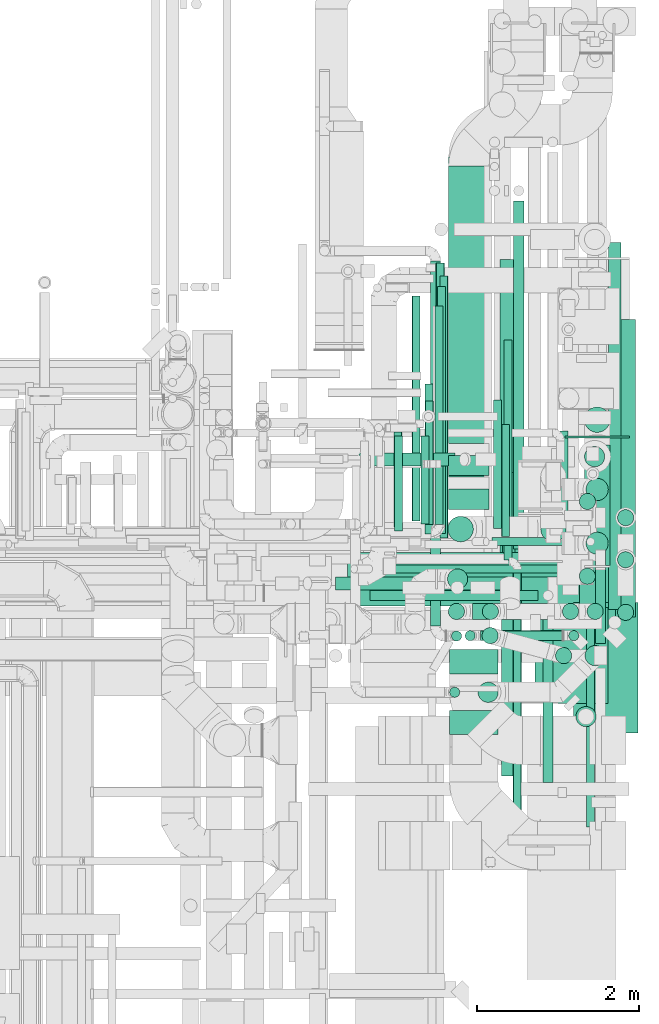
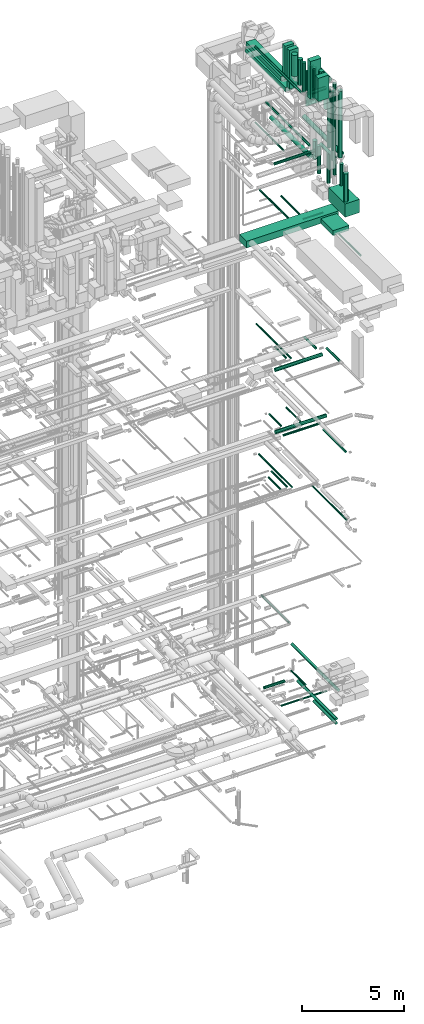
# One storey, part 82 of 337: 70 flow segments, 1 flow fitting.
"""IFC2X3 building model written with IfcOpenShell, lengths in millimetres."""

from ifc_helpers import new_model, entity, si_unit, converted_unit, derived_unit, direction, frame, origin, origin_2d_with_axis, place, context, subcontext, project, spatial, rectangle, circle, extrude, source, transform, mapped, material, type_object, type_shapes, element, save


model = new_model("IFC2X3")

# Units and contexts
model_context = context("Model", 3, precision=0.01, world=origin(), true_north=direction((6.12303176911189e-17, 1.0)))
body_context = subcontext(model_context, "Body", "Model", "MODEL_VIEW")
ifc_project = project(units=[si_unit("LENGTHUNIT", "METRE", prefix="MILLI"), si_unit("AREAUNIT", "SQUARE_METRE"), si_unit("VOLUMEUNIT", "CUBIC_METRE"), converted_unit("PLANEANGLEUNIT", "DEGREE", entity("IfcRatioMeasure", 0.0174532925199433), si_unit("PLANEANGLEUNIT", "RADIAN"), dimensions=[0, 0, 0, 0, 0, 0, 0]), si_unit("MASSUNIT", "GRAM", prefix="KILO"), derived_unit("MASSDENSITYUNIT", [(si_unit("MASSUNIT", "GRAM", prefix="KILO"), 1), (si_unit("LENGTHUNIT", "METRE"), -3)]), derived_unit("MOMENTOFINERTIAUNIT", [(si_unit("LENGTHUNIT", "METRE"), 4)]), si_unit("TIMEUNIT", "SECOND"), si_unit("FREQUENCYUNIT", "HERTZ"), si_unit("THERMODYNAMICTEMPERATUREUNIT", "DEGREE_CELSIUS"), derived_unit("THERMALTRANSMITTANCEUNIT", [(si_unit("MASSUNIT", "GRAM", prefix="KILO"), 1), (si_unit("THERMODYNAMICTEMPERATUREUNIT", "KELVIN"), -1), (si_unit("TIMEUNIT", "SECOND"), -3)]), derived_unit("VOLUMETRICFLOWRATEUNIT", [(si_unit("LENGTHUNIT", "METRE"), 3), (si_unit("TIMEUNIT", "SECOND"), -1)]), derived_unit("MASSFLOWRATEUNIT", [(si_unit("MASSUNIT", "GRAM", prefix="KILO"), 1), (si_unit("TIMEUNIT", "SECOND"), -1)]), derived_unit("ROTATIONALFREQUENCYUNIT", [(si_unit("TIMEUNIT", "SECOND"), -1)]), si_unit("ELECTRICCURRENTUNIT", "AMPERE"), si_unit("ELECTRICVOLTAGEUNIT", "VOLT"), si_unit("POWERUNIT", "WATT"), si_unit("FORCEUNIT", "NEWTON", prefix="KILO"), si_unit("ILLUMINANCEUNIT", "LUX"), si_unit("LUMINOUSFLUXUNIT", "LUMEN"), si_unit("LUMINOUSINTENSITYUNIT", "CANDELA"), derived_unit("USERDEFINED", [(si_unit("MASSUNIT", "GRAM", prefix="KILO"), -1), (si_unit("LENGTHUNIT", "METRE"), -2), (si_unit("TIMEUNIT", "SECOND"), 3), (si_unit("LUMINOUSFLUXUNIT", "LUMEN"), 1)]), derived_unit("LINEARVELOCITYUNIT", [(si_unit("LENGTHUNIT", "METRE"), 1), (si_unit("TIMEUNIT", "SECOND"), -1)]), si_unit("PRESSUREUNIT", "PASCAL"), derived_unit("USERDEFINED", [(si_unit("LENGTHUNIT", "METRE"), -2), (si_unit("MASSUNIT", "GRAM", prefix="KILO"), 1), (si_unit("TIMEUNIT", "SECOND"), -2)]), derived_unit("LINEARFORCEUNIT", [(si_unit("MASSUNIT", "GRAM", prefix="KILO"), 1), (si_unit("LENGTHUNIT", "METRE"), 1), (si_unit("TIMEUNIT", "SECOND"), -2), (si_unit("LENGTHUNIT", "METRE"), -1)]), derived_unit("PLANARFORCEUNIT", [(si_unit("MASSUNIT", "GRAM", prefix="KILO"), 1), (si_unit("LENGTHUNIT", "METRE"), 1), (si_unit("TIMEUNIT", "SECOND"), -2), (si_unit("LENGTHUNIT", "METRE"), -2)])], contexts=[model_context])

# Site, building, storey
site_placement = place(None, origin())
site = spatial("IfcSite", under=ifc_project, at=site_placement, CompositionType="ELEMENT")
building_placement = place(site_placement, origin())
building = spatial("IfcBuilding", under=site, at=building_placement, CompositionType="ELEMENT")
storey_placement = place(building_placement, origin())
storey = spatial("IfcBuildingStorey", under=building, at=storey_placement, CompositionType="ELEMENT", Elevation=0.0)

# Flow segments
duct_segment_type_1 = type_object("IfcDuctSegmentType", PredefinedType="NOTDEFINED")
flow_segment_1_placement = place(storey_placement, frame((67791.64, 9413.98, 27350.0)))
element("IfcFlowSegment", 1, at=flow_segment_1_placement, inside=storey, type_object=duct_segment_type_1, context=body_context, shape_type="SweptSolid", body=[
    extrude(rectangle(XDim=5190.00000000013, YDim=700.0, at=origin_2d_with_axis()), frame((2595.0, 350.0, 0.0)), (0.0, 0.0, 1.0), 399.999999999996),
])
flow_segment_2_placement = place(storey_placement, frame((71975.78, 8207.23, 27350.0)))
element("IfcFlowSegment", 2, at=flow_segment_2_placement, inside=storey, type_object=duct_segment_type_1, context=body_context, shape_type="SweptSolid", body=[
    extrude(rectangle(XDim=1186.60983195998, YDim=899.999999999999, at=origin_2d_with_axis()), frame((450.08, 593.37, 0.0), z_axis=(0.0, 0.0, 1.0), x_axis=(-0.000134105140809168, 0.999999991007906, 0.0)), (0.0, 0.0, 1.0), 300.000000000001),
])
flow_segment_3_placement = place(storey_placement, frame((70919.75, 7823.58, 35950.0)))
element("IfcFlowSegment", 3, at=flow_segment_3_placement, inside=storey, type_object=duct_segment_type_1, context=body_context, shape_type="SweptSolid", body=[
    extrude(rectangle(XDim=300.000000000001, YDim=600.000000000002, at=origin_2d_with_axis()), frame((300.0, 150.0, 0.0), z_axis=(0.0, 0.0, 1.0), x_axis=(0.0, -1.0, 0.0)), (0.0, 0.0, 1.0), 1380.0),
])
flow_segment_4_placement = place(storey_placement, frame((70919.75, 8574.98, 35600.0)))
element("IfcFlowSegment", 4, at=flow_segment_4_placement, inside=storey, type_object=duct_segment_type_1, context=body_context, shape_type="SweptSolid", body=[
    extrude(rectangle(XDim=300.000000000001, YDim=600.000000000002, at=origin_2d_with_axis()), frame((300.0, 150.0, 0.0), z_axis=(0.0, 0.0, 1.0), x_axis=(0.0, -1.0, 0.0)), (0.0, 0.0, 1.0), 2280.00000000001),
])
flow_segment_5_placement = place(storey_placement, frame((70907.48, 11425.0, 35010.0)))
element("IfcFlowSegment", 5, at=flow_segment_5_placement, inside=storey, type_object=duct_segment_type_1, context=body_context, shape_type="SweptSolid", body=[
    extrude(rectangle(XDim=3428.6189352427, YDim=499.999999999999, at=origin_2d_with_axis()), frame((250.0, 1714.31, 0.0), z_axis=(0.0, 0.0, 1.0), x_axis=(0.0, -1.0, 0.0)), (0.0, 0.0, 1.0), 250.000000000004),
])
flow_segment_6_placement = place(storey_placement, frame((70907.48, 11025.0, 35410.0)))
element("IfcFlowSegment", 6, at=flow_segment_6_placement, inside=storey, type_object=duct_segment_type_1, context=body_context, shape_type="SweptSolid", body=[
    extrude(rectangle(XDim=249.999999999999, YDim=499.999999999999, at=origin_2d_with_axis()), frame((250.0, 125.0, 0.0), z_axis=(0.0, 0.0, 1.0), x_axis=(0.0, 1.0, 0.0)), (0.0, 0.0, 1.0), 1905.00000000002),
])
flow_segment_7_placement = place(storey_placement, frame((70907.48, 11008.7, 34600.0)))
element("IfcFlowSegment", 7, at=flow_segment_7_placement, inside=storey, type_object=duct_segment_type_1, context=body_context, shape_type="SweptSolid", body=[
    extrude(rectangle(XDim=3954.30436019193, YDim=499.999999999999, at=origin_2d_with_axis()), frame((250.0, 1977.15, 0.0), z_axis=(0.0, 0.0, 1.0), x_axis=(0.0, -1.0, 0.0)), (0.0, 0.0, 1.0), 250.000000000004),
])
flow_segment_8_placement = place(storey_placement, frame((70907.48, 10608.7, 35000.0)))
element("IfcFlowSegment", 8, at=flow_segment_8_placement, inside=storey, type_object=duct_segment_type_1, context=body_context, shape_type="SweptSolid", body=[
    extrude(rectangle(XDim=249.999999999999, YDim=499.999999999999, at=origin_2d_with_axis()), frame((250.0, 125.0, 0.0), z_axis=(0.0, 0.0, 1.0), x_axis=(0.0, 1.0, 0.0)), (0.0, 0.0, 1.0), 2315.0),
])
flow_segment_9_placement = place(storey_placement, frame((72448.65, 7845.08, 28500.0)))
element("IfcFlowSegment", 9, at=flow_segment_9_placement, inside=storey, type_object=duct_segment_type_1, context=body_context, shape_type="SweptSolid", body=[
    extrude(rectangle(XDim=1610.00000000001, YDim=800.0, at=origin_2d_with_axis()), frame((400.0, 805.0, 0.0), z_axis=(0.0, 0.0, 1.0), x_axis=(0.0, -1.0, 0.0)), (0.0, 0.0, 1.0), 800.0),
])
duct_segment_type_2 = type_object("IfcDuctSegmentType", PredefinedType="NOTDEFINED")
flow_segment_10_placement = place(storey_placement, frame((72879.66, 9371.8, -881.6)))
element("IfcFlowSegment", 10, at=flow_segment_10_placement, inside=storey, type_object=duct_segment_type_2, context=body_context, shape_type="SweptSolid", body=[
    extrude(circle(Radius=80.0, at=origin_2d_with_axis()), frame((81.6, 0.0, 81.6), z_axis=(0.0, 1.0, 0.0), x_axis=(-1.0, 0.0, 0.0)), (0.0, 0.0, 1.0), 4537.92989),
])
flow_segment_11_placement = place(storey_placement, frame((69801.87, 11141.98, -756.6)))
element("IfcFlowSegment", 11, at=flow_segment_11_placement, inside=storey, type_object=duct_segment_type_2, context=body_context, shape_type="SweptSolid", body=[
    extrude(circle(Radius=80.0, at=origin_2d_with_axis()), frame((0.0, 81.6, 81.6), z_axis=(1.0, 0.0, 0.0), x_axis=(0.0, -1.0, 0.0)), (0.0, 0.0, 1.0), 1181.52376700002),
])
flow_segment_12_placement = place(storey_placement, frame((71568.5, 7314.74, -881.6)))
element("IfcFlowSegment", 12, at=flow_segment_12_placement, inside=storey, type_object=duct_segment_type_2, context=body_context, shape_type="SweptSolid", body=[
    extrude(circle(Radius=80.0, at=origin_2d_with_axis()), frame((81.6, 0.0, 81.6), z_axis=(0.0, 1.0, 0.0), x_axis=(-1.0, 0.0, 0.0)), (0.0, 0.0, 1.0), 3748.83497000008),
])
flow_segment_13_placement = place(storey_placement, frame((70010.28, 9821.97, -1051.6)))
element("IfcFlowSegment", 13, at=flow_segment_13_placement, inside=storey, type_object=duct_segment_type_2, context=body_context, shape_type="SweptSolid", body=[
    extrude(circle(Radius=50.0, at=origin_2d_with_axis()), frame((0.0, 51.6, 51.6), z_axis=(1.0, 0.0, 0.0), x_axis=(0.0, -1.0, 0.0)), (0.0, 0.0, 1.0), 2578.23126866774),
])
flow_segment_14_placement = place(storey_placement, frame((71561.03, 10274.06, -601.6)))
element("IfcFlowSegment", 14, at=flow_segment_14_placement, inside=storey, type_object=duct_segment_type_2, context=body_context, shape_type="SweptSolid", body=[
    extrude(circle(Radius=50.0, at=origin_2d_with_axis()), frame((51.6, 0.0, 51.6), z_axis=(2.56859086930135e-06, 1.0, 0.0), x_axis=(1.0, -2.56859086930135e-06, 0.0)), (0.0, 0.0, 1.0), 1382.69073369446),
])
flow_segment_15_placement = place(storey_placement, frame((71557.44, 7311.16, -1131.6)))
element("IfcFlowSegment", 15, at=flow_segment_15_placement, inside=storey, type_object=duct_segment_type_2, context=body_context, shape_type="SweptSolid", body=[
    extrude(circle(Radius=80.0, at=origin_2d_with_axis()), frame((81.6, 0.0, 81.6), z_axis=(0.0, 1.0, 0.0), x_axis=(-1.0, 0.0, 0.0)), (0.0, 0.0, 1.0), 2169.84771),
])
flow_segment_16_placement = place(storey_placement, frame((70238.12, 10340.36, 15248.4)))
element("IfcFlowSegment", 16, at=flow_segment_16_placement, inside=storey, type_object=duct_segment_type_2, context=body_context, shape_type="SweptSolid", body=[
    extrude(circle(Radius=50.0, at=origin_2d_with_axis()), frame((51.6, 0.0, 51.6), z_axis=(0.0, 1.0, 0.0), x_axis=(1.0, 0.0, 0.0)), (0.0, 0.0, 1.0), 1177.73964999999),
])
flow_segment_17_placement = place(storey_placement, frame((69737.94, 9873.39, 15248.4)))
element("IfcFlowSegment", 17, at=flow_segment_17_placement, inside=storey, type_object=duct_segment_type_2, context=body_context, shape_type="SweptSolid", body=[
    extrude(circle(Radius=100.0, at=origin_2d_with_axis()), frame((0.0, 101.6, 101.6), z_axis=(1.0, 0.0, 0.0), x_axis=(0.0, -1.0, 0.0)), (0.0, 0.0, 1.0), 2869.63437025001),
])
flow_segment_18_placement = place(storey_placement, frame((69936.58, 9480.25, 15285.9)))
element("IfcFlowSegment", 18, at=flow_segment_18_placement, inside=storey, type_object=duct_segment_type_2, context=body_context, shape_type="SweptSolid", body=[
    extrude(circle(Radius=62.5, at=origin_2d_with_axis()), frame((0.0, 64.1, 64.1), z_axis=(1.0, 0.0, 0.0), x_axis=(0.0, 1.0, 0.0)), (0.0, 0.0, 1.0), 2073.83664918466),
])
flow_segment_19_placement = place(storey_placement, frame((72071.32, 7232.82, 14935.9)))
element("IfcFlowSegment", 19, at=flow_segment_19_placement, inside=storey, type_object=duct_segment_type_2, context=body_context, shape_type="SweptSolid", body=[
    extrude(circle(Radius=62.5, at=origin_2d_with_axis()), frame((64.1, 0.0, 64.1), z_axis=(0.0, 1.0, 0.0), x_axis=(-1.0, 0.0, 0.0)), (0.0, 0.0, 1.0), 2186.51993999997),
])
flow_segment_20_placement = place(storey_placement, frame((71703.29, 6486.79, 11468.4)))
element("IfcFlowSegment", 20, at=flow_segment_20_placement, inside=storey, type_object=duct_segment_type_2, context=body_context, shape_type="SweptSolid", body=[
    extrude(circle(Radius=50.0, at=origin_2d_with_axis()), frame((51.6, 0.0, 51.6), z_axis=(0.0, 1.0, 0.0), x_axis=(-1.0, 0.0, 0.0)), (0.0, 0.0, 1.0), 3380.00000000001),
])
flow_segment_21_placement = place(storey_placement, frame((70227.31, 10391.33, 11448.4)))
element("IfcFlowSegment", 21, at=flow_segment_21_placement, inside=storey, type_object=duct_segment_type_2, context=body_context, shape_type="SweptSolid", body=[
    extrude(circle(Radius=50.0, at=origin_2d_with_axis()), frame((51.6, 0.0, 51.6), z_axis=(0.0, 1.0, 0.0), x_axis=(-1.0, 0.0, 0.0)), (0.0, 0.0, 1.0), 1175.00000000004),
])
flow_segment_22_placement = place(storey_placement, frame((70616.5, 10421.33, 11448.4)))
element("IfcFlowSegment", 22, at=flow_segment_22_placement, inside=storey, type_object=duct_segment_type_2, context=body_context, shape_type="SweptSolid", body=[
    extrude(circle(Radius=50.0, at=origin_2d_with_axis()), frame((51.6, 0.0, 51.6), z_axis=(0.0, 1.0, 0.0), x_axis=(-1.0, 0.0, 0.0)), (0.0, 0.0, 1.0), 1529.47216173019),
])
flow_segment_23_placement = place(storey_placement, frame((70796.11, 10255.6, 11468.4)))
element("IfcFlowSegment", 23, at=flow_segment_23_placement, inside=storey, type_object=duct_segment_type_2, context=body_context, shape_type="SweptSolid", body=[
    extrude(circle(Radius=50.0, at=origin_2d_with_axis()), frame((51.6, 0.0, 51.6), z_axis=(0.0, 1.0, 0.0), x_axis=(1.0, 0.0, 0.0)), (0.0, 0.0, 1.0), 3240.00000000001),
])
flow_segment_24_placement = place(storey_placement, frame((72720.06, 8953.57, 19085.9)))
element("IfcFlowSegment", 24, at=flow_segment_24_placement, inside=storey, type_object=duct_segment_type_2, context=body_context, shape_type="SweptSolid", body=[
    extrude(circle(Radius=62.5, at=origin_2d_with_axis()), frame((64.1, 0.0, 64.1), z_axis=(0.0, 1.0, 0.0), x_axis=(1.0, 0.0, 0.0)), (0.0, 0.0, 1.0), 1265.62499999999),
])
flow_segment_25_placement = place(storey_placement, frame((72256.63, 10469.2, 19085.9)))
element("IfcFlowSegment", 25, at=flow_segment_25_placement, inside=storey, type_object=duct_segment_type_2, context=body_context, shape_type="SweptSolid", body=[
    extrude(circle(Radius=62.5, at=origin_2d_with_axis()), frame((64.1, 0.0, 64.1), z_axis=(0.0, 1.0, 0.0), x_axis=(1.0, 0.0, 0.0)), (0.0, 0.0, 1.0), 1109.37500000001),
])
flow_segment_26_placement = place(storey_placement, frame((70752.21, 10279.05, 19148.4)))
element("IfcFlowSegment", 26, at=flow_segment_26_placement, inside=storey, type_object=duct_segment_type_2, context=body_context, shape_type="SweptSolid", body=[
    extrude(circle(Radius=50.0, at=origin_2d_with_axis()), frame((51.6, 0.0, 51.6), z_axis=(0.0, 1.0, 0.0), x_axis=(1.0, 0.0, 0.0)), (0.0, 0.0, 1.0), 3376.25000000001),
])
flow_segment_27_placement = place(storey_placement, frame((70563.23, 10425.19, 19148.4)))
element("IfcFlowSegment", 27, at=flow_segment_27_placement, inside=storey, type_object=duct_segment_type_2, context=body_context, shape_type="SweptSolid", body=[
    extrude(circle(Radius=50.0, at=origin_2d_with_axis()), frame((51.6, 0.0, 51.6), z_axis=(0.0, 1.0, 0.0), x_axis=(1.0, 0.0, 0.0)), (0.0, 0.0, 1.0), 1090.00000000002),
])
flow_segment_28_placement = place(storey_placement, frame((71459.59, 10375.04, 14948.4)))
element("IfcFlowSegment", 28, at=flow_segment_28_placement, inside=storey, type_object=duct_segment_type_2, context=body_context, shape_type="SweptSolid", body=[
    extrude(circle(Radius=50.0, at=origin_2d_with_axis()), frame((51.6, 0.0, 51.6), z_axis=(0.0, 1.0, 0.0), x_axis=(1.0, 0.0, 0.0)), (0.0, 0.0, 1.0), 1585.30000000002),
])
flow_segment_29_placement = place(storey_placement, frame((69656.48, 9772.48, 19048.4)))
element("IfcFlowSegment", 29, at=flow_segment_29_placement, inside=storey, type_object=duct_segment_type_2, context=body_context, shape_type="SweptSolid", body=[
    extrude(circle(Radius=100.0, at=origin_2d_with_axis()), frame((0.0, 101.6, 101.6), z_axis=(1.0, 0.0, 0.0), x_axis=(0.0, -1.0, 0.0)), (0.0, 0.0, 1.0), 2660.0),
])
flow_segment_30_placement = place(storey_placement, frame((72591.89, 8674.15, 31450.0)))
element("IfcFlowSegment", 30, at=flow_segment_30_placement, inside=storey, type_object=duct_segment_type_2, context=body_context, shape_type="SweptSolid", body=[
    extrude(circle(Radius=125.0, at=origin_2d_with_axis()), frame((126.6, 126.6, 0.0), z_axis=(0.0, 0.0, 1.0), x_axis=(0.0, 1.0, 0.0)), (0.0, 0.0, 1.0), 3974.99998958661),
])
flow_segment_31_placement = place(storey_placement, frame((71268.98, 8221.53, 35925.0)))
element("IfcFlowSegment", 31, at=flow_segment_31_placement, inside=storey, type_object=duct_segment_type_2, context=body_context, shape_type="SweptSolid", body=[
    extrude(circle(Radius=125.0, at=origin_2d_with_axis()), frame((126.6, 126.6, 0.0), z_axis=(0.0, 0.0, 1.0), x_axis=(0.0, 1.0, 0.0)), (0.0, 0.0, 1.0), 1405.0),
])
flow_segment_32_placement = place(storey_placement, frame((72965.22, 9277.63, 31073.4)))
element("IfcFlowSegment", 32, at=flow_segment_32_placement, inside=storey, type_object=duct_segment_type_2, context=body_context, shape_type="SweptSolid", body=[
    extrude(circle(Radius=125.0, at=origin_2d_with_axis()), frame((126.6, 0.0, 126.6), z_axis=(8.83551242385744e-08, 1.0, 0.0), x_axis=(1.0, -8.83551242385744e-08, 0.0)), (0.0, 0.0, 1.0), 3680.07185493192),
])
flow_segment_33_placement = place(storey_placement, frame((72616.89, 9246.15, 31800.0)))
element("IfcFlowSegment", 33, at=flow_segment_33_placement, inside=storey, type_object=duct_segment_type_2, context=body_context, shape_type="SweptSolid", body=[
    extrude(circle(Radius=100.0, at=origin_2d_with_axis()), frame((101.6, 101.6, 0.0), z_axis=(0.0, 0.0, 1.0), x_axis=(0.0, -1.0, 0.0)), (0.0, 0.0, 1.0), 3700.0),
])
flow_segment_34_placement = place(storey_placement, frame((72227.2, 8699.15, 31400.0)))
element("IfcFlowSegment", 34, at=flow_segment_34_placement, inside=storey, type_object=duct_segment_type_2, context=body_context, shape_type="SweptSolid", body=[
    extrude(circle(Radius=100.0, at=origin_2d_with_axis()), frame((101.6, 101.6, 0.0), z_axis=(0.0, 0.0, 1.0), x_axis=(0.0, -1.0, 0.0)), (0.0, 0.0, 1.0), 4089.99999999998),
])
flow_segment_35_placement = place(storey_placement, frame((72312.2, 9246.15, 31800.0)))
element("IfcFlowSegment", 35, at=flow_segment_35_placement, inside=storey, type_object=duct_segment_type_2, context=body_context, shape_type="SweptSolid", body=[
    extrude(circle(Radius=100.0, at=origin_2d_with_axis()), frame((101.6, 101.6, 0.0), z_axis=(0.0, 0.0, 1.0), x_axis=(0.0, -1.0, 0.0)), (0.0, 0.0, 1.0), 3400.0),
])
flow_segment_36_placement = place(storey_placement, frame((71318.99, 8946.98, 35890.0)))
element("IfcFlowSegment", 36, at=flow_segment_36_placement, inside=storey, type_object=duct_segment_type_2, context=body_context, shape_type="SweptSolid", body=[
    extrude(circle(Radius=100.0, at=origin_2d_with_axis()), frame((101.6, 101.6, 0.0), z_axis=(0.0, 0.0, 1.0), x_axis=(0.0, 1.0, 0.0)), (0.0, 0.0, 1.0), 1200.00000000002),
])
flow_segment_37_placement = place(storey_placement, frame((72389.7, 8983.65, 31775.0)))
element("IfcFlowSegment", 37, at=flow_segment_37_placement, inside=storey, type_object=duct_segment_type_2, context=body_context, shape_type="SweptSolid", body=[
    extrude(circle(Radius=62.5, at=origin_2d_with_axis()), frame((64.1, 64.1, 0.0), z_axis=(0.0, 0.0, 1.0), x_axis=(0.0, 1.0, 0.0)), (0.0, 0.0, 1.0), 3550.00000000003),
])
flow_segment_38_placement = place(storey_placement, frame((71298.8, 8983.65, 35385.9)))
element("IfcFlowSegment", 38, at=flow_segment_38_placement, inside=storey, type_object=duct_segment_type_2, context=body_context, shape_type="SweptSolid", body=[
    extrude(circle(Radius=62.5, at=origin_2d_with_axis()), frame((0.0, 64.1, 64.1), z_axis=(1.0, 0.0, 0.0), x_axis=(0.0, 1.0, 0.0)), (0.0, 0.0, 1.0), 1030.00000000001),
])
flow_segment_39_placement = place(storey_placement, frame((71109.7, 8983.65, 35575.0)))
element("IfcFlowSegment", 39, at=flow_segment_39_placement, inside=storey, type_object=duct_segment_type_2, context=body_context, shape_type="SweptSolid", body=[
    extrude(circle(Radius=62.5, at=origin_2d_with_axis()), frame((64.1, 64.1, 0.0), z_axis=(0.0, 0.0, 1.0), x_axis=(0.0, 1.0, 0.0)), (0.0, 0.0, 1.0), 1675.00000000001),
])
flow_segment_40_placement = place(storey_placement, frame((71321.89, 9246.15, 35900.0)))
element("IfcFlowSegment", 40, at=flow_segment_40_placement, inside=storey, type_object=duct_segment_type_2, context=body_context, shape_type="SweptSolid", body=[
    extrude(circle(Radius=100.0, at=origin_2d_with_axis()), frame((101.6, 101.6, 0.0), z_axis=(0.0, 0.0, 1.0), x_axis=(0.0, 1.0, 0.0)), (0.0, 0.0, 1.0), 1140.00000000002),
])
flow_segment_41_placement = place(storey_placement, frame((71203.8, 9246.15, 35298.4)))
element("IfcFlowSegment", 41, at=flow_segment_41_placement, inside=storey, type_object=duct_segment_type_2, context=body_context, shape_type="SweptSolid", body=[
    extrude(circle(Radius=100.0, at=origin_2d_with_axis()), frame((0.0, 101.6, 101.6), z_axis=(1.0, 0.0, 0.0), x_axis=(0.0, 1.0, 0.0)), (0.0, 0.0, 1.0), 1009.99999999998),
])
flow_segment_42_placement = place(storey_placement, frame((70902.2, 9246.15, 35600.0)))
element("IfcFlowSegment", 42, at=flow_segment_42_placement, inside=storey, type_object=duct_segment_type_2, context=body_context, shape_type="SweptSolid", body=[
    extrude(circle(Radius=100.0, at=origin_2d_with_axis()), frame((101.6, 101.6, 0.0), z_axis=(0.0, 0.0, 1.0), x_axis=(0.0, 1.0, 0.0)), (0.0, 0.0, 1.0), 1760.00000000002),
])
flow_segment_43_placement = place(storey_placement, frame((70891.5, 9622.1, 35800.0)))
element("IfcFlowSegment", 43, at=flow_segment_43_placement, inside=storey, type_object=duct_segment_type_2, context=body_context, shape_type="SweptSolid", body=[
    extrude(circle(Radius=125.0, at=origin_2d_with_axis()), frame((126.6, 126.6, 0.0), z_axis=(0.0, 0.0, 1.0), x_axis=(0.0, -1.0, 0.0)), (0.0, 0.0, 1.0), 1530.00000000002),
])
flow_segment_44_placement = place(storey_placement, frame((70680.49, 9168.62, 35675.9)))
element("IfcFlowSegment", 44, at=flow_segment_44_placement, inside=storey, type_object=duct_segment_type_2, context=body_context, shape_type="SweptSolid", body=[
    extrude(circle(Radius=62.5, at=origin_2d_with_axis()), frame((64.1, 0.0, 64.1), z_axis=(0.0, 1.0, 0.0), x_axis=(1.0, 0.0, 0.0)), (0.0, 0.0, 1.0), 4511.38396375113),
])
flow_segment_45_placement = place(storey_placement, frame((72044.01, 10206.55, 34220.0)))
element("IfcFlowSegment", 45, at=flow_segment_45_placement, inside=storey, type_object=duct_segment_type_2, context=body_context, shape_type="SweptSolid", body=[
    extrude(circle(Radius=157.5, at=origin_2d_with_axis()), frame((159.1, 159.1, 0.0), z_axis=(0.0, 0.0, 1.0), x_axis=(-1.0, 0.0, 0.0)), (0.0, 0.0, 1.0), 1105.00000000002),
])
flow_segment_46_placement = place(storey_placement, frame((72584.01, 11558.55, 33716.26)))
element("IfcFlowSegment", 46, at=flow_segment_46_placement, inside=storey, type_object=duct_segment_type_2, context=body_context, shape_type="SweptSolid", body=[
    extrude(circle(Radius=157.5, at=origin_2d_with_axis()), frame((159.1, 159.1, 0.0)), (0.0, 0.0, 1.0), 1308.74275466218),
])
flow_segment_47_placement = place(storey_placement, frame((70896.16, 10206.55, 35955.0)))
element("IfcFlowSegment", 47, at=flow_segment_47_placement, inside=storey, type_object=duct_segment_type_2, context=body_context, shape_type="SweptSolid", body=[
    extrude(circle(Radius=157.5, at=origin_2d_with_axis()), frame((159.1, 159.1, 0.0), z_axis=(0.0, 0.0, 1.0), x_axis=(0.0, 1.0, 0.0)), (0.0, 0.0, 1.0), 1264.95702892504),
])
flow_segment_48_placement = place(storey_placement, frame((72584.01, 9917.65, 35180.9)))
element("IfcFlowSegment", 48, at=flow_segment_48_placement, inside=storey, type_object=duct_segment_type_2, context=body_context, shape_type="SweptSolid", body=[
    extrude(circle(Radius=157.5, at=origin_2d_with_axis()), frame((159.1, 0.0, 159.1), z_axis=(0.0, 1.0, 0.0), x_axis=(-1.0, 0.0, 0.0)), (0.0, 0.0, 1.0), 1485.00000000002),
])
flow_segment_49_placement = place(storey_placement, frame((72604.01, 10716.05, 33510.07)))
element("IfcFlowSegment", 49, at=flow_segment_49_placement, inside=storey, type_object=duct_segment_type_2, context=body_context, shape_type="SweptSolid", body=[
    extrude(circle(Radius=137.5, at=origin_2d_with_axis()), frame((139.1, 139.1, 0.0)), (0.0, 0.0, 1.0), 1652.42985290827),
])
flow_segment_50_placement = place(storey_placement, frame((72604.01, 10051.05, 33510.07)))
element("IfcFlowSegment", 50, at=flow_segment_50_placement, inside=storey, type_object=duct_segment_type_2, context=body_context, shape_type="SweptSolid", body=[
    extrude(circle(Radius=137.5, at=origin_2d_with_axis()), frame((139.1, 139.1, 0.0), z_axis=(0.0, 0.0, 1.0), x_axis=(-1.0, 0.0, 0.0)), (0.0, 0.0, 1.0), 1652.42985290824),
])
flow_segment_51_placement = place(storey_placement, frame((70941.16, 8979.52, 35865.0)))
element("IfcFlowSegment", 51, at=flow_segment_51_placement, inside=storey, type_object=duct_segment_type_2, context=body_context, shape_type="SweptSolid", body=[
    extrude(circle(Radius=62.5, at=origin_2d_with_axis()), frame((64.1, 64.1, 0.0), z_axis=(0.0, 0.0, 1.0), x_axis=(0.0, -1.0, 0.0)), (0.0, 0.0, 1.0), 1167.50000000001),
])
flow_segment_52_placement = place(storey_placement, frame((70918.36, 8284.03, 35875.0)))
element("IfcFlowSegment", 52, at=flow_segment_52_placement, inside=storey, type_object=duct_segment_type_2, context=body_context, shape_type="SweptSolid", body=[
    extrude(circle(Radius=62.5, at=origin_2d_with_axis()), frame((64.1, 64.1, 0.0), z_axis=(0.0, 0.0, 1.0), x_axis=(0.0, -1.0, 0.0)), (0.0, 0.0, 1.0), 1677.5),
])
flow_segment_53_placement = place(storey_placement, frame((70769.27, 10309.98, 27308.4)))
element("IfcFlowSegment", 53, at=flow_segment_53_placement, inside=storey, type_object=duct_segment_type_2, context=body_context, shape_type="SweptSolid", body=[
    extrude(circle(Radius=50.0, at=origin_2d_with_axis()), frame((51.6, 0.0, 51.6), z_axis=(0.0, 1.0, 0.0), x_axis=(1.0, 0.0, 0.0)), (0.0, 0.0, 1.0), 3051.27499999997),
])
flow_segment_54_placement = place(storey_placement, frame((70613.28, 10305.08, 27548.4)))
element("IfcFlowSegment", 54, at=flow_segment_54_placement, inside=storey, type_object=duct_segment_type_2, context=body_context, shape_type="SweptSolid", body=[
    extrude(circle(Radius=50.0, at=origin_2d_with_axis()), frame((51.6, 0.0, 51.6), z_axis=(0.0, 1.0, 0.0), x_axis=(1.0, 0.0, 0.0)), (0.0, 0.0, 1.0), 1855.00000000002),
])
flow_segment_55_placement = place(storey_placement, frame((72521.04, 9177.43, 31098.4)))
element("IfcFlowSegment", 55, at=flow_segment_55_placement, inside=storey, type_object=duct_segment_type_2, context=body_context, shape_type="SweptSolid", body=[
    extrude(circle(Radius=100.0, at=origin_2d_with_axis()), frame((101.6, 0.0, 101.6), z_axis=(0.0, 1.0, 0.0), x_axis=(1.0, 0.0, 0.0)), (0.0, 0.0, 1.0), 1330.05134385226),
])
flow_segment_56_placement = place(storey_placement, frame((72521.04, 10605.88, 29350.0)))
element("IfcFlowSegment", 56, at=flow_segment_56_placement, inside=storey, type_object=duct_segment_type_2, context=body_context, shape_type="SweptSolid", body=[
    extrude(circle(Radius=100.0, at=origin_2d_with_axis()), frame((101.6, 101.6, 0.0)), (0.0, 0.0, 1.0), 1650.00000000003),
])
flow_segment_57_placement = place(storey_placement, frame((72521.04, 9680.88, 29350.0)))
element("IfcFlowSegment", 57, at=flow_segment_57_placement, inside=storey, type_object=duct_segment_type_2, context=body_context, shape_type="SweptSolid", body=[
    extrude(circle(Radius=100.0, at=origin_2d_with_axis()), frame((101.6, 101.6, 0.0)), (0.0, 0.0, 1.0), 1729.99999999999),
])
flow_segment_58_placement = place(storey_placement, frame((71540.22, 9850.24, 31073.4)))
element("IfcFlowSegment", 58, at=flow_segment_58_placement, inside=storey, type_object=duct_segment_type_2, context=body_context, shape_type="SweptSolid", body=[
    extrude(circle(Radius=125.0, at=origin_2d_with_axis()), frame((126.6, 0.0, 126.6), z_axis=(0.0, 1.0, 0.0), x_axis=(1.0, 0.0, 0.0)), (0.0, 0.0, 1.0), 3845.61980025205),
])
flow_segment_59_placement = place(storey_placement, frame((72585.22, 11133.98, 29880.0)))
element("IfcFlowSegment", 59, at=flow_segment_59_placement, inside=storey, type_object=duct_segment_type_2, context=body_context, shape_type="SweptSolid", body=[
    extrude(circle(Radius=125.0, at=origin_2d_with_axis()), frame((126.6, 126.6, 0.0), z_axis=(0.0, 0.0, 1.0), x_axis=(0.0, -1.0, 0.0)), (0.0, 0.0, 1.0), 1070.0),
])
flow_segment_60_placement = place(storey_placement, frame((71709.7, 10120.25, 31575.9)))
element("IfcFlowSegment", 60, at=flow_segment_60_placement, inside=storey, type_object=duct_segment_type_2, context=body_context, shape_type="SweptSolid", body=[
    extrude(circle(Radius=62.5, at=origin_2d_with_axis()), frame((64.1, 0.0, 64.1), z_axis=(0.0, 1.0, 0.0), x_axis=(-1.0, 0.0, 0.0)), (0.0, 0.0, 1.0), 4302.50000000002),
])
flow_segment_61_placement = place(storey_placement, frame((72993.38, 9234.77, 29320.0)))
element("IfcFlowSegment", 61, at=flow_segment_61_placement, inside=storey, type_object=duct_segment_type_2, context=body_context, shape_type="SweptSolid", body=[
    extrude(circle(Radius=100.0, at=origin_2d_with_axis()), frame((101.6, 101.6, 0.0), z_axis=(0.0, 0.0, 1.0), x_axis=(-1.0, 0.0, 0.0)), (0.0, 0.0, 1.0), 1280.0),
])
flow_segment_62_placement = place(storey_placement, frame((72993.38, 10404.77, 29550.0)))
element("IfcFlowSegment", 62, at=flow_segment_62_placement, inside=storey, type_object=duct_segment_type_2, context=body_context, shape_type="SweptSolid", body=[
    extrude(circle(Radius=100.0, at=origin_2d_with_axis()), frame((101.6, 101.6, 0.0), z_axis=(0.0, 0.0, 1.0), x_axis=(-1.0, 0.0, 0.0)), (0.0, 0.0, 1.0), 1050.00000000001),
])
flow_segment_63_placement = place(storey_placement, frame((72993.38, 9884.77, 29550.0)))
element("IfcFlowSegment", 63, at=flow_segment_63_placement, inside=storey, type_object=duct_segment_type_2, context=body_context, shape_type="SweptSolid", body=[
    extrude(circle(Radius=100.0, at=origin_2d_with_axis()), frame((101.6, 101.6, 0.0), z_axis=(0.0, 0.0, 1.0), x_axis=(-1.0, 0.0, 0.0)), (0.0, 0.0, 1.0), 1130.0),
])
flow_segment_64_placement = place(storey_placement, frame((69511.53, 9611.82, 31518.4)))
element("IfcFlowSegment", 64, at=flow_segment_64_placement, inside=storey, type_object=duct_segment_type_2, context=body_context, shape_type="SweptSolid", body=[
    extrude(circle(Radius=80.0, at=origin_2d_with_axis()), frame((0.0, 81.6, 81.6), z_axis=(1.0, 0.0, 0.0), x_axis=(0.0, 1.0, 0.0)), (0.0, 0.0, 1.0), 2298.58175439435),
])
flow_segment_65_placement = place(storey_placement, frame((70454.7, 10466.4, 31518.4)))
element("IfcFlowSegment", 65, at=flow_segment_65_placement, inside=storey, type_object=duct_segment_type_2, context=body_context, shape_type="SweptSolid", body=[
    extrude(circle(Radius=50.0, at=origin_2d_with_axis()), frame((51.6, 0.0, 51.6), z_axis=(0.0, 1.0, 0.0), x_axis=(1.0, 0.0, 0.0)), (0.0, 0.0, 1.0), 2782.02041028867),
])
flow_segment_66_placement = place(storey_placement, frame((71588.63, 9981.53, 27068.4)))
element("IfcFlowSegment", 66, at=flow_segment_66_placement, inside=storey, type_object=duct_segment_type_2, context=body_context, shape_type="SweptSolid", body=[
    extrude(circle(Radius=50.0, at=origin_2d_with_axis()), frame((51.6, 0.0, 51.6), z_axis=(0.0, 1.0, 0.0), x_axis=(-1.0, 0.0, 0.0)), (0.0, 0.0, 1.0), 2718.44762635842),
])
flow_segment_67_placement = place(storey_placement, frame((72609.78, 6681.53, 26798.4)))
element("IfcFlowSegment", 67, at=flow_segment_67_placement, inside=storey, type_object=duct_segment_type_2, context=body_context, shape_type="SweptSolid", body=[
    extrude(circle(Radius=50.0, at=origin_2d_with_axis()), frame((51.6, 0.0, 51.6), z_axis=(0.0, 1.0, 0.0), x_axis=(-1.0, 0.0, 0.0)), (0.0, 0.0, 1.0), 3428.44762635842),
])
flow_segment_68_placement = place(storey_placement, frame((70736.14, 10424.99, 3298.4)))
element("IfcFlowSegment", 68, at=flow_segment_68_placement, inside=storey, type_object=duct_segment_type_2, context=body_context, shape_type="SweptSolid", body=[
    extrude(circle(Radius=50.0, at=origin_2d_with_axis()), frame((51.6, 0.0, 51.6), z_axis=(0.0, 1.0, 0.0), x_axis=(1.0, 0.0, 0.0)), (0.0, 0.0, 1.0), 2697.59999999997),
])
flow_segment_69_placement = place(storey_placement, frame((72478.59, 7920.38, 29320.0)))
element("IfcFlowSegment", 69, at=flow_segment_69_placement, inside=storey, type_object=duct_segment_type_2, context=body_context, shape_type="SweptSolid", body=[
    extrude(circle(Radius=125.0, at=origin_2d_with_axis()), frame((126.6, 126.6, 0.0), z_axis=(0.0, 0.0, 1.0), x_axis=(-0.707106781186564, -0.707106781186531, 0.0)), (0.0, 0.0, 1.0), 1669.99999999999),
])
flow_segment_70_placement = place(storey_placement, frame((71441.92, 10158.38, 27268.4)))
element("IfcFlowSegment", 70, at=flow_segment_70_placement, inside=storey, type_object=duct_segment_type_2, context=body_context, shape_type="SweptSolid", body=[
    extrude(circle(Radius=50.0, at=origin_2d_with_axis()), frame((0.0, 51.6, 51.6), z_axis=(1.0, 0.0, 0.0), x_axis=(0.0, -1.0, 0.0)), (0.0, 0.0, 1.0), 1119.45669763334),
])

# Flow fitting
ifc_material = material()
duct_fitting_type = type_object("IfcDuctFittingType", PredefinedType="NOTDEFINED", material=ifc_material)
shared_shape = source(origin(), body_context, "Body", "SweptSolid", [
    extrude(rectangle(XDim=24.9999999999999, YDim=800.0, at=origin_2d_with_axis()), frame((12.5, 0.0, -375.0)), (0.0, 0.0, 1.0), 750.0),
])
type_shapes(duct_fitting_type, [shared_shape])
flow_fitting_placement = place(storey_placement, frame((72743.11, 11515.31, 33321.26), z_axis=(0.0, 0.0, 1.0), x_axis=(0.0, -1.0, 0.0)))
element("IfcFlowFitting", 71, at=flow_fitting_placement, inside=storey, type_object=duct_fitting_type, material=ifc_material, context=body_context, shape_type="MappedRepresentation", body=[
    mapped(shared_shape, transform((0.0, 0.0, 0.0), scale=1.0)),
])

save(model, "model.ifc")
